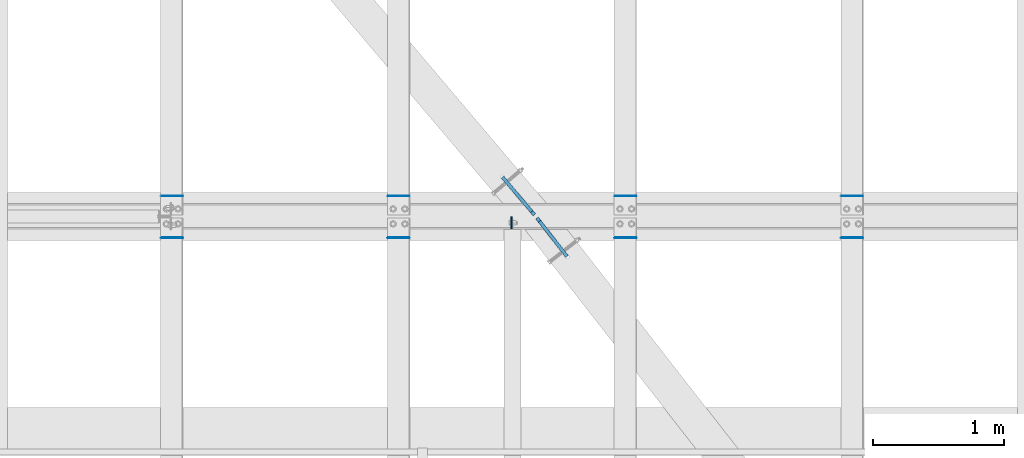
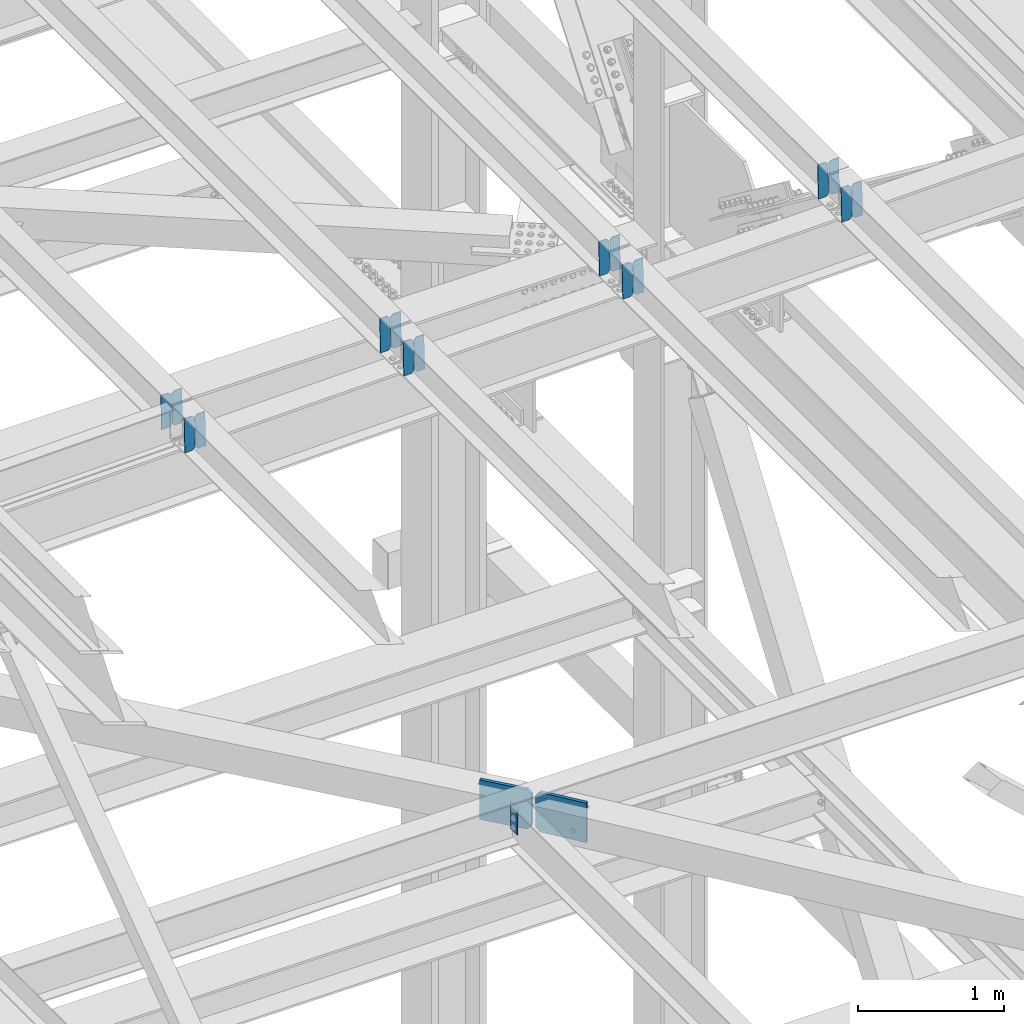
# One storey, part 3571 of 3843: 19 plates, 9 elements without a shape of their own.
"""IFC2X3 building model written with IfcOpenShell, lengths in millimetres."""

from ifc_helpers import new_model, si_unit, frame, origin_with_axes, place, context, subcontext, project, spatial, faceted_brep, material, type_object, element, aggregate, save


model = new_model("IFC2X3")

# Units and contexts
model_context = context("Model", 3, precision=1e-05, world=origin_with_axes())
body_context = subcontext(model_context, "Body", "Model", "MODEL_VIEW")
ifc_project = project(units=[si_unit("LENGTHUNIT", "METRE", prefix="MILLI"), si_unit("AREAUNIT", "SQUARE_METRE"), si_unit("VOLUMEUNIT", "CUBIC_METRE"), si_unit("MASSUNIT", "GRAM", prefix="KILO"), si_unit("TIMEUNIT", "SECOND"), si_unit("PLANEANGLEUNIT", "RADIAN"), si_unit("SOLIDANGLEUNIT", "STERADIAN"), si_unit("THERMODYNAMICTEMPERATUREUNIT", "DEGREE_CELSIUS"), si_unit("LUMINOUSINTENSITYUNIT", "LUMEN")], contexts=[model_context])

# Site, building, storey
site_placement = place(None, origin_with_axes())
site = spatial("IfcSite", under=ifc_project, at=site_placement, CompositionType="ELEMENT")
building_placement = place(site_placement, origin_with_axes())
building = spatial("IfcBuilding", under=site, at=building_placement, Name="Undefined", CompositionType="ELEMENT")
storey_placement = place(building_placement, origin_with_axes())
storey = spatial("IfcBuildingStorey", under=building, at=storey_placement, Name="Undefined", CompositionType="ELEMENT", Elevation=0.0)

# Assembly, plate
assembly_1_placement = place(storey_placement, origin_with_axes())
assembly_1 = element("IfcElementAssembly", 1, at=assembly_1_placement, inside=storey, Name="BEAM", AssemblyPlace="NOTDEFINED", PredefinedType="RIGID_FRAME")
ifc_material = material(Name="STEEL/A572-50")
plate_type_1 = type_object("IfcPlateType", PredefinedType="NOTDEFINED")
plate_1_placement = place(assembly_1_placement, frame((81322.8625, 20303.33125, 42384.6625), z_axis=(0.0, -1.0, 0.0), x_axis=(0.0, 0.0, -1.0)))
plate_1 = element("IfcPlate", 2, at=plate_1_placement, type_object=plate_type_1, material=ifc_material, Name="PLATE", context=body_context, shape_type="Brep", body=[
    faceted_brep([(0.0, -4.76249999999709, 0.0), (0.0, -4.76249999999709, 88.9000015258789), (0.0, 4.76249999999709, 88.9000015258789), (0.0, 4.76249999999709, 0.0), (228.600006102781, -4.7625000004191, 88.9000015257589), (228.600006102781, 4.76249999954598, 88.9000015257443), (228.600006103079, -4.7625000004482, 7.27595761418343e-12), (228.600006103079, 4.76249999954598, -7.27595761418343e-12)], [[[0, 1, 2, 3]], [[1, 4, 5, 2]], [[4, 6, 7, 5]], [[6, 0, 3, 7]], [[5, 7, 3, 2]], [[6, 4, 1, 0]]]),
])

# Assembly, plates
assembly_2_placement = place(storey_placement, origin_with_axes())
assembly_2 = element("IfcElementAssembly", 3, at=assembly_2_placement, inside=storey, Name="BEAM", AssemblyPlace="NOTDEFINED", PredefinedType="RIGID_FRAME")
plate_type_2 = type_object("IfcPlateType", PredefinedType="NOTDEFINED")
plate_2_placement = place(assembly_2_placement, frame((84003.8964783493, 20462.875, 46432.9140160759), z_axis=(-0.0211520980073474, 0.0, 0.999776269347241), x_axis=(-0.999776270257024, 0.0, -0.0211520550054595)))
plate_2 = element("IfcPlate", 4, at=plate_2_placement, type_object=plate_type_2, material=ifc_material, Name="PLATE", context=body_context, shape_type="Brep", body=[
    faceted_brep([(0.0, -3.17499999999927, 0.0), (6.83940015733242e-10, -3.17499999996653, 288.924999998613), (6.54836185276508e-10, 3.17500000001746, 288.924999998591), (0.0, 3.17499999999927, 0.0), (60.3250007643655, -3.17500000017753, 288.924999998606), (60.3250007643219, 3.17499999979918, 288.924999998584), (79.3750000013097, -3.17500000025029, 269.875000761494), (79.375000001266, 3.17499999972642, 269.875000761487), (79.375000000713, -3.17500000026484, 19.0499992370605), (79.3750000006985, 3.17499999971187, 19.0499992370533), (60.325000763667, -3.17500000020664, -1.45519152283669e-11), (60.3250007636234, 3.17499999977736, -3.63797880709171e-11)], [[[0, 1, 2, 3]], [[1, 4, 5, 2]], [[4, 6, 7, 5]], [[6, 8, 9, 7]], [[8, 10, 11, 9]], [[10, 0, 3, 11]], [[5, 7, 9, 11, 3, 2]], [[10, 8, 6, 4, 1, 0]]]),
])
plate_3_placement = place(assembly_2_placement, frame((83918.1906576591, 20462.875, 46431.1007524742), z_axis=(-0.0211520980073474, 0.0, 0.999776269347241), x_axis=(-0.999776270257024, 0.0, -0.0211520550054595)))
plate_3 = element("IfcPlate", 5, at=plate_3_placement, type_object=plate_type_2, material=ifc_material, Name="PLATE", context=body_context, shape_type="Brep", body=[
    faceted_brep([(4.36557456851006e-11, -3.17499999998836, 19.0499992370969), (6.11180439591408e-10, -3.17499999996653, 269.875000761516), (5.96628524363041e-10, 3.17500000001746, 269.875000761502), (1.45519152283669e-11, 3.17499999998836, 19.0499992370824), (19.0499992376572, -3.17500000003201, 288.924999998606), (19.0499992376281, 3.1749999999447, 288.924999998584), (79.3750000013242, -3.17500000025029, 288.924999998591), (79.3750000013097, 3.1749999997337, 288.92499999857), (79.3750000006548, -3.17500000026484, -2.18278728425503e-11), (79.3750000006403, 3.17499999969732, -2.91038304567337e-11), (19.0499992370023, -3.17500000005384, 0.0), (19.0499992369587, 3.17499999992287, -1.45519152283669e-11)], [[[0, 1, 2, 3]], [[1, 4, 5, 2]], [[4, 6, 7, 5]], [[6, 8, 9, 7]], [[8, 10, 11, 9]], [[10, 0, 3, 11]], [[5, 7, 9, 11, 3, 2]], [[10, 8, 6, 4, 1, 0]]]),
])
aggregate(assembly_2, [plate_2, plate_3])

assembly_3_placement = place(storey_placement, origin_with_axes())
assembly_3 = element("IfcElementAssembly", 6, at=assembly_3_placement, inside=storey, Name="BEAM", AssemblyPlace="NOTDEFINED", PredefinedType="RIGID_FRAME")
plate_4_placement = place(assembly_3_placement, frame((84003.896478346, 20145.375, 46432.9140160799), z_axis=(-0.0211520980073474, 0.0, 0.999776269347241), x_axis=(-0.999776270257024, 0.0, -0.0211520550054595)))
plate_4 = element("IfcPlate", 7, at=plate_4_placement, type_object=plate_type_2, material=ifc_material, Name="PLATE", context=body_context, shape_type="Brep", body=[
    faceted_brep([(0.0, -3.17499999999927, 0.0), (6.83940015733242e-10, -3.17499999996653, 288.924999998613), (6.54836185276508e-10, 3.17500000001746, 288.924999998591), (0.0, 3.17499999999927, 0.0), (60.3250007643655, -3.17500000017753, 288.924999998606), (60.3250007643219, 3.17499999979918, 288.924999998584), (79.3750000013097, -3.17500000025029, 269.875000761494), (79.375000001266, 3.17499999972642, 269.875000761487), (79.375000000713, -3.17500000026484, 19.0499992370605), (79.3750000006985, 3.17499999971187, 19.0499992370533), (60.325000763667, -3.17500000020664, -1.45519152283669e-11), (60.3250007636234, 3.17499999977736, -3.63797880709171e-11)], [[[0, 1, 2, 3]], [[1, 4, 5, 2]], [[4, 6, 7, 5]], [[6, 8, 9, 7]], [[8, 10, 11, 9]], [[10, 0, 3, 11]], [[5, 7, 9, 11, 3, 2]], [[10, 8, 6, 4, 1, 0]]]),
])
plate_5_placement = place(assembly_3_placement, frame((83918.1906576557, 20145.375, 46431.1007524781), z_axis=(-0.0211520980073474, 0.0, 0.999776269347241), x_axis=(-0.999776270257024, 0.0, -0.0211520550054595)))
plate_5 = element("IfcPlate", 8, at=plate_5_placement, type_object=plate_type_2, material=ifc_material, Name="PLATE", context=body_context, shape_type="Brep", body=[
    faceted_brep([(4.36557456851006e-11, -3.17499999998836, 19.0499992370969), (6.11180439591408e-10, -3.17499999996653, 269.875000761516), (5.96628524363041e-10, 3.17500000001746, 269.875000761502), (1.45519152283669e-11, 3.17499999998836, 19.0499992370824), (19.0499992376572, -3.17500000003201, 288.924999998606), (19.0499992376281, 3.1749999999447, 288.924999998584), (79.3750000013242, -3.17500000025029, 288.924999998591), (79.3750000013097, 3.1749999997337, 288.92499999857), (79.3750000006548, -3.17500000026484, -2.18278728425503e-11), (79.3750000006403, 3.17499999969732, -2.91038304567337e-11), (19.0499992370023, -3.17500000005384, 0.0), (19.0499992369587, 3.17499999992287, -1.45519152283669e-11)], [[[0, 1, 2, 3]], [[1, 4, 5, 2]], [[4, 6, 7, 5]], [[6, 8, 9, 7]], [[8, 10, 11, 9]], [[10, 0, 3, 11]], [[5, 7, 9, 11, 3, 2]], [[10, 8, 6, 4, 1, 0]]]),
])
aggregate(assembly_3, [plate_4, plate_5])

assembly_4_placement = place(storey_placement, origin_with_axes())
assembly_4 = element("IfcElementAssembly", 9, at=assembly_4_placement, inside=storey, Name="BEAM", AssemblyPlace="NOTDEFINED", PredefinedType="RIGID_FRAME")
plate_6_placement = place(assembly_4_placement, frame((82276.6964783494, 20462.875, 46396.3719368147), z_axis=(-0.0211520980073474, 0.0, 0.999776269347241), x_axis=(-0.999776270257024, 0.0, -0.0211520550054595)))
plate_6 = element("IfcPlate", 10, at=plate_6_placement, type_object=plate_type_2, material=ifc_material, Name="PLATE", context=body_context, shape_type="Brep", body=[
    faceted_brep([(0.0, -3.17499999999927, 0.0), (6.83940015733242e-10, -3.17499999996653, 288.924999998613), (6.54836185276508e-10, 3.17500000001746, 288.924999998591), (0.0, 3.17499999999927, 0.0), (60.3250007643655, -3.17500000017753, 288.924999998606), (60.3250007643219, 3.17499999979918, 288.924999998584), (79.3750000013097, -3.17500000025029, 269.875000761494), (79.375000001266, 3.17499999972642, 269.875000761487), (79.375000000713, -3.17500000026484, 19.0499992370605), (79.3750000006985, 3.17499999971187, 19.0499992370533), (60.325000763667, -3.17500000020664, -1.45519152283669e-11), (60.3250007636234, 3.17499999977736, -3.63797880709171e-11)], [[[0, 1, 2, 3]], [[1, 4, 5, 2]], [[4, 6, 7, 5]], [[6, 8, 9, 7]], [[8, 10, 11, 9]], [[10, 0, 3, 11]], [[5, 7, 9, 11, 3, 2]], [[10, 8, 6, 4, 1, 0]]]),
])
plate_7_placement = place(assembly_4_placement, frame((82190.9906576591, 20462.875, 46394.5586732129), z_axis=(-0.0211520980073474, 0.0, 0.999776269347241), x_axis=(-0.999776270257024, 0.0, -0.0211520550054595)))
plate_7 = element("IfcPlate", 11, at=plate_7_placement, type_object=plate_type_2, material=ifc_material, Name="PLATE", context=body_context, shape_type="Brep", body=[
    faceted_brep([(4.36557456851006e-11, -3.17499999998836, 19.0499992370969), (6.11180439591408e-10, -3.17499999996653, 269.875000761516), (5.96628524363041e-10, 3.17500000001746, 269.875000761502), (1.45519152283669e-11, 3.17499999998836, 19.0499992370824), (19.0499992376572, -3.17500000003201, 288.924999998606), (19.0499992376281, 3.1749999999447, 288.924999998584), (79.3750000013242, -3.17500000025029, 288.924999998591), (79.3750000013097, 3.1749999997337, 288.92499999857), (79.3750000006548, -3.17500000026484, -2.18278728425503e-11), (79.3750000006403, 3.17499999969732, -2.91038304567337e-11), (19.0499992370023, -3.17500000005384, 0.0), (19.0499992369587, 3.17499999992287, -1.45519152283669e-11)], [[[0, 1, 2, 3]], [[1, 4, 5, 2]], [[4, 6, 7, 5]], [[6, 8, 9, 7]], [[8, 10, 11, 9]], [[10, 0, 3, 11]], [[5, 7, 9, 11, 3, 2]], [[10, 8, 6, 4, 1, 0]]]),
])
aggregate(assembly_4, [plate_6, plate_7])

assembly_5_placement = place(storey_placement, origin_with_axes())
assembly_5 = element("IfcElementAssembly", 12, at=assembly_5_placement, inside=storey, Name="BEAM", AssemblyPlace="NOTDEFINED", PredefinedType="RIGID_FRAME")
plate_8_placement = place(assembly_5_placement, frame((82276.696478346, 20145.375, 46396.3719368186), z_axis=(-0.0211520980073474, 0.0, 0.999776269347241), x_axis=(-0.999776270257024, 0.0, -0.0211520550054595)))
plate_8 = element("IfcPlate", 13, at=plate_8_placement, type_object=plate_type_2, material=ifc_material, Name="PLATE", context=body_context, shape_type="Brep", body=[
    faceted_brep([(0.0, -3.17499999999927, 0.0), (6.83940015733242e-10, -3.17499999996653, 288.924999998613), (6.54836185276508e-10, 3.17500000001746, 288.924999998591), (0.0, 3.17499999999927, 0.0), (60.3250007643655, -3.17500000017753, 288.924999998606), (60.3250007643219, 3.17499999979918, 288.924999998584), (79.3750000013097, -3.17500000025029, 269.875000761494), (79.375000001266, 3.17499999972642, 269.875000761487), (79.375000000713, -3.17500000026484, 19.0499992370605), (79.3750000006985, 3.17499999971187, 19.0499992370533), (60.325000763667, -3.17500000020664, -1.45519152283669e-11), (60.3250007636234, 3.17499999977736, -3.63797880709171e-11)], [[[0, 1, 2, 3]], [[1, 4, 5, 2]], [[4, 6, 7, 5]], [[6, 8, 9, 7]], [[8, 10, 11, 9]], [[10, 0, 3, 11]], [[5, 7, 9, 11, 3, 2]], [[10, 8, 6, 4, 1, 0]]]),
])
plate_9_placement = place(assembly_5_placement, frame((82190.9906576557, 20145.375, 46394.5586732169), z_axis=(-0.0211520980073474, 0.0, 0.999776269347241), x_axis=(-0.999776270257024, 0.0, -0.0211520550054595)))
plate_9 = element("IfcPlate", 14, at=plate_9_placement, type_object=plate_type_2, material=ifc_material, Name="PLATE", context=body_context, shape_type="Brep", body=[
    faceted_brep([(4.36557456851006e-11, -3.17499999998836, 19.0499992370969), (6.11180439591408e-10, -3.17499999996653, 269.875000761516), (5.96628524363041e-10, 3.17500000001746, 269.875000761502), (1.45519152283669e-11, 3.17499999998836, 19.0499992370824), (19.0499992376572, -3.17500000003201, 288.924999998606), (19.0499992376281, 3.1749999999447, 288.924999998584), (79.3750000013242, -3.17500000025029, 288.924999998591), (79.3750000013097, 3.1749999997337, 288.92499999857), (79.3750000006548, -3.17500000026484, -2.18278728425503e-11), (79.3750000006403, 3.17499999969732, -2.91038304567337e-11), (19.0499992370023, -3.17500000005384, 0.0), (19.0499992369587, 3.17499999992287, -1.45519152283669e-11)], [[[0, 1, 2, 3]], [[1, 4, 5, 2]], [[4, 6, 7, 5]], [[6, 8, 9, 7]], [[8, 10, 11, 9]], [[10, 0, 3, 11]], [[5, 7, 9, 11, 3, 2]], [[10, 8, 6, 4, 1, 0]]]),
])
aggregate(assembly_5, [plate_8, plate_9])

assembly_6_placement = place(storey_placement, origin_with_axes())
assembly_6 = element("IfcElementAssembly", 15, at=assembly_6_placement, inside=storey, Name="BEAM", AssemblyPlace="NOTDEFINED", PredefinedType="RIGID_FRAME")
plate_10_placement = place(assembly_6_placement, frame((80549.4964783493, 20462.875, 46359.8298575534), z_axis=(-0.0211520980073474, 0.0, 0.999776269347241), x_axis=(-0.999776270257024, 0.0, -0.0211520550054595)))
plate_10 = element("IfcPlate", 16, at=plate_10_placement, type_object=plate_type_2, material=ifc_material, Name="PLATE", context=body_context, shape_type="Brep", body=[
    faceted_brep([(0.0, -3.17499999999927, 0.0), (6.83940015733242e-10, -3.17499999996653, 288.924999998613), (6.54836185276508e-10, 3.17500000001746, 288.924999998591), (0.0, 3.17499999999927, 0.0), (60.3250007643655, -3.17500000017753, 288.924999998606), (60.3250007643219, 3.17499999979918, 288.924999998584), (79.3750000013097, -3.17500000025029, 269.875000761494), (79.375000001266, 3.17499999972642, 269.875000761487), (79.375000000713, -3.17500000026484, 19.0499992370605), (79.3750000006985, 3.17499999971187, 19.0499992370533), (60.325000763667, -3.17500000020664, -1.45519152283669e-11), (60.3250007636234, 3.17499999977736, -3.63797880709171e-11)], [[[0, 1, 2, 3]], [[1, 4, 5, 2]], [[4, 6, 7, 5]], [[6, 8, 9, 7]], [[8, 10, 11, 9]], [[10, 0, 3, 11]], [[5, 7, 9, 11, 3, 2]], [[10, 8, 6, 4, 1, 0]]]),
])
plate_11_placement = place(assembly_6_placement, frame((80463.790657659, 20462.875, 46358.0165939517), z_axis=(-0.0211520980073474, 0.0, 0.999776269347241), x_axis=(-0.999776270257024, 0.0, -0.0211520550054595)))
plate_11 = element("IfcPlate", 17, at=plate_11_placement, type_object=plate_type_2, material=ifc_material, Name="PLATE", context=body_context, shape_type="Brep", body=[
    faceted_brep([(4.36557456851006e-11, -3.17499999998836, 19.0499992370969), (6.11180439591408e-10, -3.17499999996653, 269.875000761516), (5.96628524363041e-10, 3.17500000001746, 269.875000761502), (1.45519152283669e-11, 3.17499999998836, 19.0499992370824), (19.0499992376572, -3.17500000003201, 288.924999998606), (19.0499992376281, 3.1749999999447, 288.924999998584), (79.3750000013242, -3.17500000025029, 288.924999998591), (79.3750000013097, 3.1749999997337, 288.92499999857), (79.3750000006548, -3.17500000026484, -2.18278728425503e-11), (79.3750000006403, 3.17499999969732, -2.91038304567337e-11), (19.0499992370023, -3.17500000005384, 0.0), (19.0499992369587, 3.17499999992287, -1.45519152283669e-11)], [[[0, 1, 2, 3]], [[1, 4, 5, 2]], [[4, 6, 7, 5]], [[6, 8, 9, 7]], [[8, 10, 11, 9]], [[10, 0, 3, 11]], [[5, 7, 9, 11, 3, 2]], [[10, 8, 6, 4, 1, 0]]]),
])
aggregate(assembly_6, [plate_10, plate_11])

assembly_7_placement = place(storey_placement, origin_with_axes())
assembly_7 = element("IfcElementAssembly", 18, at=assembly_7_placement, inside=storey, Name="BEAM", AssemblyPlace="NOTDEFINED", PredefinedType="RIGID_FRAME")
plate_12_placement = place(assembly_7_placement, frame((80549.496478346, 20145.375, 46359.8298575573), z_axis=(-0.0211520980073474, 0.0, 0.999776269347241), x_axis=(-0.999776270257024, 0.0, -0.0211520550054595)))
plate_12 = element("IfcPlate", 19, at=plate_12_placement, type_object=plate_type_2, material=ifc_material, Name="PLATE", context=body_context, shape_type="Brep", body=[
    faceted_brep([(0.0, -3.17499999999927, 0.0), (6.83940015733242e-10, -3.17499999996653, 288.924999998613), (6.54836185276508e-10, 3.17500000001746, 288.924999998591), (0.0, 3.17499999999927, 0.0), (60.3250007643655, -3.17500000017753, 288.924999998606), (60.3250007643219, 3.17499999979918, 288.924999998584), (79.3750000013097, -3.17500000025029, 269.875000761494), (79.375000001266, 3.17499999972642, 269.875000761487), (79.375000000713, -3.17500000026484, 19.0499992370605), (79.3750000006985, 3.17499999971187, 19.0499992370533), (60.325000763667, -3.17500000020664, -1.45519152283669e-11), (60.3250007636234, 3.17499999977736, -3.63797880709171e-11)], [[[0, 1, 2, 3]], [[1, 4, 5, 2]], [[4, 6, 7, 5]], [[6, 8, 9, 7]], [[8, 10, 11, 9]], [[10, 0, 3, 11]], [[5, 7, 9, 11, 3, 2]], [[10, 8, 6, 4, 1, 0]]]),
])
plate_13_placement = place(assembly_7_placement, frame((80463.7906576556, 20145.375, 46358.0165939556), z_axis=(-0.0211520980073474, 0.0, 0.999776269347241), x_axis=(-0.999776270257024, 0.0, -0.0211520550054595)))
plate_13 = element("IfcPlate", 20, at=plate_13_placement, type_object=plate_type_2, material=ifc_material, Name="PLATE", context=body_context, shape_type="Brep", body=[
    faceted_brep([(4.36557456851006e-11, -3.17499999998836, 19.0499992370969), (6.11180439591408e-10, -3.17499999996653, 269.875000761516), (5.96628524363041e-10, 3.17500000001746, 269.875000761502), (1.45519152283669e-11, 3.17499999998836, 19.0499992370824), (19.0499992376572, -3.17500000003201, 288.924999998606), (19.0499992376281, 3.1749999999447, 288.924999998584), (79.3750000013242, -3.17500000025029, 288.924999998591), (79.3750000013097, 3.1749999997337, 288.92499999857), (79.3750000006548, -3.17500000026484, -2.18278728425503e-11), (79.3750000006403, 3.17499999969732, -2.91038304567337e-11), (19.0499992370023, -3.17500000005384, 0.0), (19.0499992369587, 3.17499999992287, -1.45519152283669e-11)], [[[0, 1, 2, 3]], [[1, 4, 5, 2]], [[4, 6, 7, 5]], [[6, 8, 9, 7]], [[8, 10, 11, 9]], [[10, 0, 3, 11]], [[5, 7, 9, 11, 3, 2]], [[10, 8, 6, 4, 1, 0]]]),
])
aggregate(assembly_7, [plate_12, plate_13])

assembly_8_placement = place(storey_placement, origin_with_axes())
assembly_8 = element("IfcElementAssembly", 21, at=assembly_8_placement, inside=storey, Name="BEAM", AssemblyPlace="NOTDEFINED", PredefinedType="RIGID_FRAME")
plate_14_placement = place(assembly_8_placement, frame((78822.2964783494, 20462.875, 46323.2877782931), z_axis=(-0.0211520980073474, 0.0, 0.999776269347241), x_axis=(-0.999776270257024, 0.0, -0.0211520550054595)))
plate_14 = element("IfcPlate", 22, at=plate_14_placement, type_object=plate_type_2, material=ifc_material, Name="PLATE", context=body_context, shape_type="Brep", body=[
    faceted_brep([(0.0, -3.17499999999927, 0.0), (6.83940015733242e-10, -3.17499999996653, 288.924999998613), (6.54836185276508e-10, 3.17500000001746, 288.924999998591), (0.0, 3.17499999999927, 0.0), (60.3250007643655, -3.17500000017753, 288.924999998606), (60.3250007643219, 3.17499999979918, 288.924999998584), (79.3750000013097, -3.17500000025029, 269.875000761494), (79.375000001266, 3.17499999972642, 269.875000761487), (79.375000000713, -3.17500000026484, 19.0499992370605), (79.3750000006985, 3.17499999971187, 19.0499992370533), (60.325000763667, -3.17500000020664, -1.45519152283669e-11), (60.3250007636234, 3.17499999977736, -3.63797880709171e-11)], [[[0, 1, 2, 3]], [[1, 4, 5, 2]], [[4, 6, 7, 5]], [[6, 8, 9, 7]], [[8, 10, 11, 9]], [[10, 0, 3, 11]], [[5, 7, 9, 11, 3, 2]], [[10, 8, 6, 4, 1, 0]]]),
])
plate_15_placement = place(assembly_8_placement, frame((78736.5906576591, 20462.875, 46321.4745146914), z_axis=(-0.0211520980073474, 0.0, 0.999776269347241), x_axis=(-0.999776270257024, 0.0, -0.0211520550054595)))
plate_15 = element("IfcPlate", 23, at=plate_15_placement, type_object=plate_type_2, material=ifc_material, Name="PLATE", context=body_context, shape_type="Brep", body=[
    faceted_brep([(4.36557456851006e-11, -3.17499999998836, 19.0499992370969), (6.11180439591408e-10, -3.17499999996653, 269.875000761516), (5.96628524363041e-10, 3.17500000001746, 269.875000761502), (1.45519152283669e-11, 3.17499999998836, 19.0499992370824), (19.0499992376572, -3.17500000003201, 288.924999998606), (19.0499992376281, 3.1749999999447, 288.924999998584), (79.3750000013242, -3.17500000025029, 288.924999998591), (79.3750000013097, 3.1749999997337, 288.92499999857), (79.3750000006548, -3.17500000026484, -2.18278728425503e-11), (79.3750000006403, 3.17499999969732, -2.91038304567337e-11), (19.0499992370023, -3.17500000005384, 0.0), (19.0499992369587, 3.17499999992287, -1.45519152283669e-11)], [[[0, 1, 2, 3]], [[1, 4, 5, 2]], [[4, 6, 7, 5]], [[6, 8, 9, 7]], [[8, 10, 11, 9]], [[10, 0, 3, 11]], [[5, 7, 9, 11, 3, 2]], [[10, 8, 6, 4, 1, 0]]]),
])
aggregate(assembly_8, [plate_14, plate_15])

assembly_9_placement = place(storey_placement, origin_with_axes())
assembly_9 = element("IfcElementAssembly", 24, at=assembly_9_placement, inside=storey, Name="BEAM", AssemblyPlace="NOTDEFINED", PredefinedType="RIGID_FRAME")
plate_16_placement = place(assembly_9_placement, frame((78822.296478346, 20145.375, 46323.2877782971), z_axis=(-0.0211520980073474, 0.0, 0.999776269347241), x_axis=(-0.999776270257024, 0.0, -0.0211520550054595)))
plate_16 = element("IfcPlate", 25, at=plate_16_placement, type_object=plate_type_2, material=ifc_material, Name="PLATE", context=body_context, shape_type="Brep", body=[
    faceted_brep([(0.0, -3.17499999999927, 0.0), (6.83940015733242e-10, -3.17499999996653, 288.924999998613), (6.54836185276508e-10, 3.17500000001746, 288.924999998591), (0.0, 3.17499999999927, 0.0), (60.3250007643655, -3.17500000017753, 288.924999998606), (60.3250007643219, 3.17499999979918, 288.924999998584), (79.3750000013097, -3.17500000025029, 269.875000761494), (79.375000001266, 3.17499999972642, 269.875000761487), (79.375000000713, -3.17500000026484, 19.0499992370605), (79.3750000006985, 3.17499999971187, 19.0499992370533), (60.325000763667, -3.17500000020664, -1.45519152283669e-11), (60.3250007636234, 3.17499999977736, -3.63797880709171e-11)], [[[0, 1, 2, 3]], [[1, 4, 5, 2]], [[4, 6, 7, 5]], [[6, 8, 9, 7]], [[8, 10, 11, 9]], [[10, 0, 3, 11]], [[5, 7, 9, 11, 3, 2]], [[10, 8, 6, 4, 1, 0]]]),
])
plate_17_placement = place(assembly_9_placement, frame((78736.5906576557, 20145.375, 46321.4745146954), z_axis=(-0.0211520980073474, 0.0, 0.999776269347241), x_axis=(-0.999776270257024, 0.0, -0.0211520550054595)))
plate_17 = element("IfcPlate", 26, at=plate_17_placement, type_object=plate_type_2, material=ifc_material, Name="PLATE", context=body_context, shape_type="Brep", body=[
    faceted_brep([(4.36557456851006e-11, -3.17499999998836, 19.0499992370969), (6.11180439591408e-10, -3.17499999996653, 269.875000761516), (5.96628524363041e-10, 3.17500000001746, 269.875000761502), (1.45519152283669e-11, 3.17499999998836, 19.0499992370824), (19.0499992376572, -3.17500000003201, 288.924999998606), (19.0499992376281, 3.1749999999447, 288.924999998584), (79.3750000013242, -3.17500000025029, 288.924999998591), (79.3750000013097, 3.1749999997337, 288.92499999857), (79.3750000006548, -3.17500000026484, -2.18278728425503e-11), (79.3750000006403, 3.17499999969732, -2.91038304567337e-11), (19.0499992370023, -3.17500000005384, 0.0), (19.0499992369587, 3.17499999992287, -1.45519152283669e-11)], [[[0, 1, 2, 3]], [[1, 4, 5, 2]], [[4, 6, 7, 5]], [[6, 8, 9, 7]], [[8, 10, 11, 9]], [[10, 0, 3, 11]], [[5, 7, 9, 11, 3, 2]], [[10, 8, 6, 4, 1, 0]]]),
])
aggregate(assembly_9, [plate_16, plate_17])

# Plate
plate_type_3 = type_object("IfcPlateType", PredefinedType="NOTDEFINED")
plate_18_placement = place(assembly_1_placement, frame((81747.4446512935, 20001.0513367754, 42081.45), z_axis=(0.0, 0.0, 1.0), x_axis=(-0.614984883006892, 0.788538898008842, 0.0)))
plate_18 = element("IfcPlate", 27, at=plate_18_placement, type_object=plate_type_3, material=ifc_material, Name="STIFFENER", context=body_context, shape_type="Brep", body=[
    faceted_brep([(0.0, -12.6999999999971, 0.0), (0.0, -12.6999999999825, 330.199999999997), (-1.45519152283669e-11, 12.699999999968, 330.199999999997), (0.0, 12.6999999999971, 0.0), (341.687006037362, -12.6999999994441, 330.199999999997), (341.687006037333, 12.7000000005064, 330.199999999997), (373.437006037449, -12.6999999994005, 298.449999999997), (373.437006037428, 12.7000000005501, 298.449999999997), (373.437006037449, -12.6999999994005, 31.75), (373.437006037428, 12.7000000005501, 31.75), (341.687006037362, -12.6999999994441, 0.0), (341.687006037333, 12.7000000005064, 0.0)], [[[0, 1, 2, 3]], [[1, 4, 5, 2]], [[4, 6, 7, 5]], [[6, 8, 9, 7]], [[8, 10, 11, 9]], [[10, 0, 3, 11]], [[5, 7, 9, 11, 3, 2]], [[10, 8, 6, 4, 1, 0]]]),
])

plate_19_placement = place(assembly_1_placement, frame((81498.3293748077, 20319.4217211219, 42081.45), z_axis=(0.0, 0.0, 1.0), x_axis=(-0.646262043041127, 0.763115569048561, 0.0)))
plate_19 = element("IfcPlate", 28, at=plate_19_placement, type_object=plate_type_3, material=ifc_material, Name="STIFFENER", context=body_context, shape_type="Brep", body=[
    faceted_brep([(0.0, -12.7000000000262, 31.7500000000218), (-7.27595761418343e-12, -12.699999999968, 298.449999999997), (0.0, 12.699999999968, 298.449999999997), (0.0, 12.699999999837, 31.75000000008), (31.74999999992, -12.6999999999825, 330.199999999997), (31.7499999999272, 12.6999999999534, 330.199999999997), (377.605404686874, -12.700000000099, 330.199999999997), (377.605404686874, 12.699999999837, 330.199999999997), (377.605404686874, -12.700000000099, 0.0), (377.605404686874, 12.699999999837, 0.0), (31.75, -12.6999999999389, -2.91038304567337e-11), (31.75, 12.6999999999098, 2.91038304567337e-11)], [[[0, 1, 2, 3]], [[1, 4, 5, 2]], [[4, 6, 7, 5]], [[6, 8, 9, 7]], [[8, 10, 11, 9]], [[10, 0, 3, 11]], [[5, 7, 9, 11, 3, 2]], [[10, 8, 6, 4, 1, 0]]]),
])

aggregate(assembly_1, [plate_18, plate_19, plate_1])

save(model, "model.ifc")
